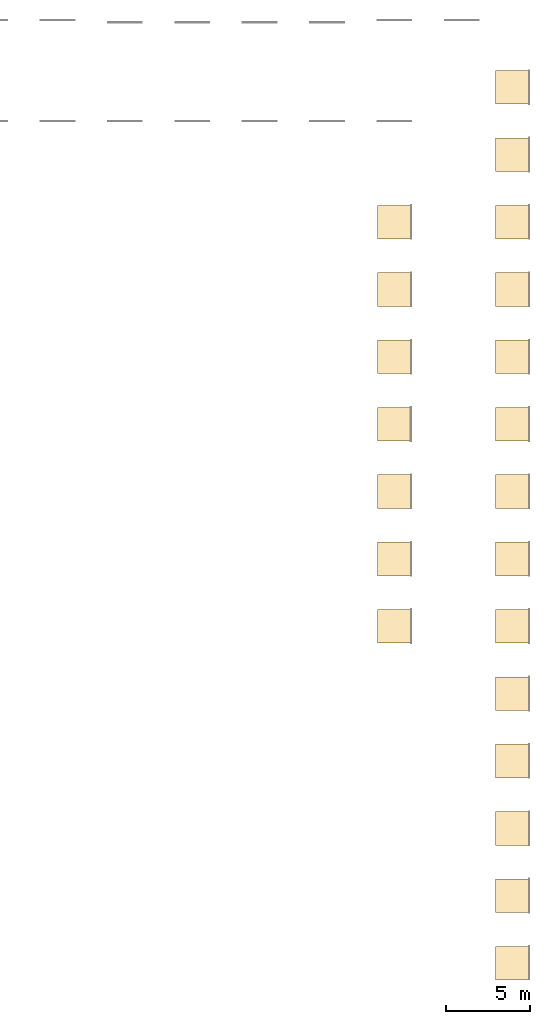
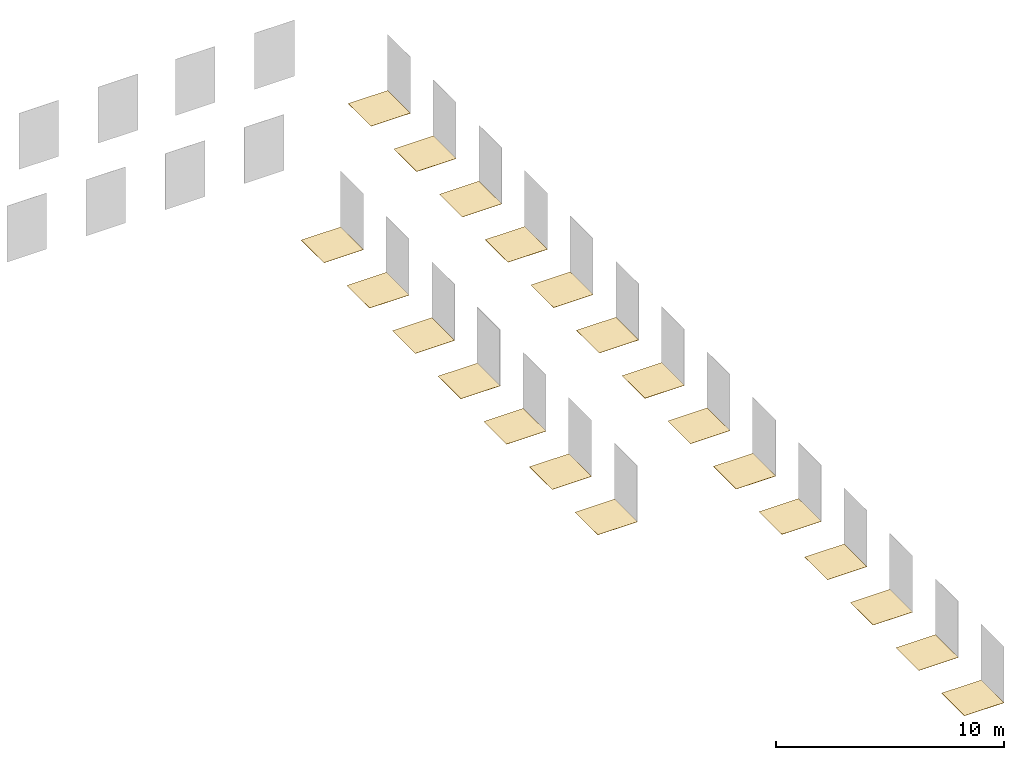
# One storey, part 2 of 2: 21 coverings.
"""IFC2X3 building model written with IfcOpenShell, lengths in millimetres."""

from ifc_helpers import new_model, entity, si_unit, converted_unit, derived_unit, direction, frame, frame_2d, origin, place, context, subcontext, project, spatial, rectangle, extrude, material, layer, layer_set, layer_usage, element, save


model = new_model("IFC2X3")

# Units and contexts
model_context = context("Model", 3, precision=0.01, world=origin(), true_north=direction((6.12303176911189e-17, 1.0)))
body_context = subcontext(model_context, "Body", "Model", "MODEL_VIEW")
ifc_project = project(units=[si_unit("LENGTHUNIT", "METRE", prefix="MILLI"), si_unit("AREAUNIT", "SQUARE_METRE"), si_unit("VOLUMEUNIT", "CUBIC_METRE"), converted_unit("PLANEANGLEUNIT", "DEGREE", entity("IfcRatioMeasure", 0.0174532925199433), si_unit("PLANEANGLEUNIT", "RADIAN"), dimensions=[0, 0, 0, 0, 0, 0, 0]), si_unit("MASSUNIT", "GRAM", prefix="KILO"), derived_unit("MASSDENSITYUNIT", [(si_unit("MASSUNIT", "GRAM", prefix="KILO"), 1), (si_unit("LENGTHUNIT", "METRE"), -3)]), si_unit("TIMEUNIT", "SECOND"), si_unit("FREQUENCYUNIT", "HERTZ"), si_unit("THERMODYNAMICTEMPERATUREUNIT", "DEGREE_CELSIUS"), derived_unit("THERMALTRANSMITTANCEUNIT", [(si_unit("MASSUNIT", "GRAM", prefix="KILO"), 1), (si_unit("THERMODYNAMICTEMPERATUREUNIT", "KELVIN"), -1), (si_unit("TIMEUNIT", "SECOND"), -3)]), derived_unit("VOLUMETRICFLOWRATEUNIT", [(si_unit("LENGTHUNIT", "METRE"), 3), (si_unit("TIMEUNIT", "SECOND"), -1)]), si_unit("ELECTRICCURRENTUNIT", "AMPERE"), si_unit("ELECTRICVOLTAGEUNIT", "VOLT"), si_unit("POWERUNIT", "WATT"), si_unit("FORCEUNIT", "NEWTON", prefix="KILO"), si_unit("ILLUMINANCEUNIT", "LUX"), si_unit("LUMINOUSFLUXUNIT", "LUMEN"), si_unit("LUMINOUSINTENSITYUNIT", "CANDELA"), derived_unit("USERDEFINED", [(si_unit("MASSUNIT", "GRAM", prefix="KILO"), -1), (si_unit("LENGTHUNIT", "METRE"), -2), (si_unit("TIMEUNIT", "SECOND"), 3), (si_unit("LUMINOUSFLUXUNIT", "LUMEN"), 1)]), derived_unit("LINEARVELOCITYUNIT", [(si_unit("LENGTHUNIT", "METRE"), 1), (si_unit("TIMEUNIT", "SECOND"), -1)]), si_unit("PRESSUREUNIT", "PASCAL"), derived_unit("USERDEFINED", [(si_unit("LENGTHUNIT", "METRE"), -2), (si_unit("MASSUNIT", "GRAM", prefix="KILO"), 1), (si_unit("TIMEUNIT", "SECOND"), -2)])], contexts=[model_context])

# Site, building, storey
site_placement = place(None, origin())
site = spatial("IfcSite", under=ifc_project, at=site_placement, CompositionType="ELEMENT")
building_placement = place(site_placement, origin())
building = spatial("IfcBuilding", under=site, at=building_placement, CompositionType="ELEMENT")
storey_placement = place(building_placement, origin())
storey = spatial("IfcBuildingStorey", under=building, at=storey_placement, Name="Level 1", CompositionType="ELEMENT", Elevation=0.0)

# Coverings
ifc_material_1 = material()
ifc_layer_1 = layer(ifc_material_1, 10.5)
ifc_layer_set_1 = layer_set([ifc_layer_1])
ifc_layer_usage_1 = layer_usage(ifc_layer_set_1, "AXIS3", "POSITIVE", 0.0)
covering_1_placement = place(storey_placement, origin())
element("IfcCovering", 1, at=covering_1_placement, inside=storey, material=ifc_layer_usage_1, PredefinedType="FLOORING", context=body_context, shape_type="SweptSolid", body=[
    extrude(rectangle(XDim=2000.0, YDim=2000.0, at=frame_2d((2.8421709430404e-13, 1.13686837721616e-13), x_axis=(1.0, 0.0))), frame((2527.07742659013, -3501.98267476882, 0.0), z_axis=(0.0, 0.0, -1.0), x_axis=(0.0, 1.0, 0.0)), (0.0, 0.0, 1.0), 10.5),
])
ifc_material_2 = material()
ifc_layer_2 = layer(ifc_material_2, 10.5)
ifc_layer_set_2 = layer_set([ifc_layer_2])
ifc_layer_usage_2 = layer_usage(ifc_layer_set_2, "AXIS3", "POSITIVE", 0.0)
covering_2_placement = place(storey_placement, origin())
element("IfcCovering", 2, at=covering_2_placement, inside=storey, material=ifc_layer_usage_2, PredefinedType="FLOORING", context=body_context, shape_type="SweptSolid", body=[
    extrude(rectangle(XDim=2000.0, YDim=2000.0, at=frame_2d((5.6843418860808e-13, 1.13686837721616e-13), x_axis=(1.0, 0.0))), frame((2527.07742659012, -7501.98267476882, 0.0), z_axis=(0.0, 0.0, -1.0), x_axis=(0.0, 1.0, 0.0)), (0.0, 0.0, 1.0), 10.5),
])
ifc_material_3 = material()
ifc_layer_3 = layer(ifc_material_3, 10.5)
ifc_layer_set_3 = layer_set([ifc_layer_3])
ifc_layer_usage_3 = layer_usage(ifc_layer_set_3, "AXIS3", "POSITIVE", 0.0)
covering_3_placement = place(storey_placement, origin())
element("IfcCovering", 3, at=covering_3_placement, inside=storey, material=ifc_layer_usage_3, PredefinedType="FLOORING", context=body_context, shape_type="SweptSolid", body=[
    extrude(rectangle(XDim=2000.0, YDim=2000.0, at=frame_2d((-2.8421709430404e-13, 1.13686837721616e-13), x_axis=(1.0, 0.0))), frame((2527.07742659014, 4498.01732523118, 0.0), z_axis=(0.0, 0.0, -1.0), x_axis=(0.0, 1.0, 0.0)), (0.0, 0.0, 1.0), 10.5),
])
ifc_material_4 = material()
ifc_layer_4 = layer(ifc_material_4, 10.5)
ifc_layer_set_4 = layer_set([ifc_layer_4])
ifc_layer_usage_4 = layer_usage(ifc_layer_set_4, "AXIS3", "POSITIVE", 0.0)
covering_4_placement = place(storey_placement, origin())
element("IfcCovering", 4, at=covering_4_placement, inside=storey, material=ifc_layer_usage_4, PredefinedType="FLOORING", context=body_context, shape_type="SweptSolid", body=[
    extrude(rectangle(XDim=2000.0, YDim=2000.0, at=frame_2d((-1.13686837721616e-13, 1.13686837721616e-13), x_axis=(1.0, 0.0))), frame((2527.07742659014, 498.017325231177, 0.0), z_axis=(0.0, 0.0, -1.0), x_axis=(0.0, 1.0, 0.0)), (0.0, 0.0, 1.0), 10.5),
])
ifc_material_5 = material()
ifc_layer_5 = layer(ifc_material_5, 10.5)
ifc_layer_set_5 = layer_set([ifc_layer_5])
ifc_layer_usage_5 = layer_usage(ifc_layer_set_5, "AXIS3", "POSITIVE", 0.0)
covering_5_placement = place(storey_placement, origin())
element("IfcCovering", 5, at=covering_5_placement, inside=storey, material=ifc_layer_usage_5, PredefinedType="FLOORING", context=body_context, shape_type="SweptSolid", body=[
    extrude(rectangle(XDim=2000.0, YDim=2000.0, at=frame_2d((0.0, 1.13686837721616e-13), x_axis=(1.0, 0.0))), frame((2527.07742659012, -11501.9826747688, 0.0), z_axis=(0.0, 0.0, -1.0), x_axis=(0.0, 1.0, 0.0)), (0.0, 0.0, 1.0), 10.5),
])
ifc_material_6 = material()
ifc_layer_6 = layer(ifc_material_6, 10.5)
ifc_layer_set_6 = layer_set([ifc_layer_6])
ifc_layer_usage_6 = layer_usage(ifc_layer_set_6, "AXIS3", "POSITIVE", 0.0)
covering_6_placement = place(storey_placement, origin())
element("IfcCovering", 6, at=covering_6_placement, inside=storey, material=ifc_layer_usage_6, PredefinedType="FLOORING", context=body_context, shape_type="SweptSolid", body=[
    extrude(rectangle(XDim=2000.0, YDim=2000.0, at=frame_2d((0.0, 1.13686837721616e-13), x_axis=(1.0, 0.0))), frame((2527.07742659011, -15501.9826747688, 0.0), z_axis=(0.0, 0.0, -1.0), x_axis=(0.0, 1.0, 0.0)), (0.0, 0.0, 1.0), 10.5),
])
ifc_material_7 = material()
ifc_layer_7 = layer(ifc_material_7, 11.5)
ifc_layer_set_7 = layer_set([ifc_layer_7])
ifc_layer_usage_7 = layer_usage(ifc_layer_set_7, "AXIS3", "POSITIVE", 0.0)
covering_7_placement = place(storey_placement, origin())
element("IfcCovering", 7, at=covering_7_placement, inside=storey, material=ifc_layer_usage_7, PredefinedType="FLOORING", context=body_context, shape_type="SweptSolid", body=[
    extrude(rectangle(XDim=2000.0, YDim=2000.0, at=frame_2d((0.0, 1.13686837721616e-13), x_axis=(1.0, 0.0))), frame((2527.07742659011, -19501.9826747688, 0.0), z_axis=(0.0, 0.0, -1.0), x_axis=(0.0, 1.0, 0.0)), (0.0, 0.0, 1.0), 11.5),
])
ifc_material_8 = material()
ifc_layer_8 = layer(ifc_material_8, 11.5)
ifc_layer_set_8 = layer_set([ifc_layer_8])
ifc_layer_usage_8 = layer_usage(ifc_layer_set_8, "AXIS3", "POSITIVE", 0.0)
covering_8_placement = place(storey_placement, origin())
element("IfcCovering", 8, at=covering_8_placement, inside=storey, material=ifc_layer_usage_8, PredefinedType="FLOORING", context=body_context, shape_type="SweptSolid", body=[
    extrude(rectangle(XDim=2000.0, YDim=2000.0, at=frame_2d((0.0, 1.13686837721616e-13), x_axis=(1.0, 0.0))), frame((2527.0774265901, -23501.9826747688, 0.0), z_axis=(0.0, 0.0, -1.0), x_axis=(0.0, 1.0, 0.0)), (0.0, 0.0, 1.0), 11.5),
])
ifc_material_9 = material()
ifc_layer_9 = layer(ifc_material_9, 11.5)
ifc_layer_set_9 = layer_set([ifc_layer_9])
ifc_layer_usage_9 = layer_usage(ifc_layer_set_9, "AXIS3", "POSITIVE", 0.0)
covering_9_placement = place(storey_placement, origin())
element("IfcCovering", 9, at=covering_9_placement, inside=storey, material=ifc_layer_usage_9, PredefinedType="CLADDING", context=body_context, shape_type="SweptSolid", body=[
    extrude(rectangle(XDim=2000.0, YDim=2000.0, at=frame_2d((0.0, 1.13686837721616e-13), x_axis=(1.0, 0.0))), frame((2527.07742659009, -27501.9826747688, 0.0), z_axis=(0.0, 0.0, -1.0), x_axis=(0.0, 1.0, 0.0)), (0.0, 0.0, 1.0), 11.5),
])
ifc_material_10 = material()
ifc_layer_10 = layer(ifc_material_10, 11.5)
ifc_layer_set_10 = layer_set([ifc_layer_10])
ifc_layer_usage_10 = layer_usage(ifc_layer_set_10, "AXIS3", "POSITIVE", 0.0)
covering_10_placement = place(storey_placement, origin())
element("IfcCovering", 10, at=covering_10_placement, inside=storey, material=ifc_layer_usage_10, PredefinedType="FLOORING", context=body_context, shape_type="SweptSolid", body=[
    extrude(rectangle(XDim=2000.0, YDim=2000.0, at=frame_2d((0.0, 1.13686837721616e-13), x_axis=(1.0, 0.0))), frame((2527.07742659009, -31501.9826747688, 0.0), z_axis=(0.0, 0.0, -1.0), x_axis=(0.0, 1.0, 0.0)), (0.0, 0.0, 1.0), 11.5),
])
ifc_material_11 = material()
ifc_layer_11 = layer(ifc_material_11, 9.4)
ifc_layer_set_11 = layer_set([ifc_layer_11])
ifc_layer_usage_11 = layer_usage(ifc_layer_set_11, "AXIS3", "POSITIVE", 0.0)
covering_11_placement = place(storey_placement, origin())
element("IfcCovering", 11, at=covering_11_placement, inside=storey, material=ifc_layer_usage_11, PredefinedType="FLOORING", context=body_context, shape_type="SweptSolid", body=[
    extrude(rectangle(XDim=2000.0, YDim=2000.0, at=frame_2d((0.0, 1.13686837721616e-13), x_axis=(1.0, 0.0))), frame((2527.07742659008, -35501.9826747688, 0.0), z_axis=(0.0, 0.0, -1.0), x_axis=(0.0, 1.0, 0.0)), (0.0, 0.0, 1.0), 9.4),
])
ifc_material_12 = material()
ifc_layer_12 = layer(ifc_material_12, 9.4)
ifc_layer_set_12 = layer_set([ifc_layer_12])
ifc_layer_usage_12 = layer_usage(ifc_layer_set_12, "AXIS3", "POSITIVE", 0.0)
covering_12_placement = place(storey_placement, origin())
element("IfcCovering", 12, at=covering_12_placement, inside=storey, material=ifc_layer_usage_12, PredefinedType="FLOORING", context=body_context, shape_type="SweptSolid", body=[
    extrude(rectangle(XDim=2000.0, YDim=2000.0, at=frame_2d((2.1600499167107e-12, 1.13686837721616e-13), x_axis=(1.0, 0.0))), frame((2527.07742659007, -39501.9826747688, 0.0), z_axis=(0.0, 0.0, -1.0), x_axis=(0.0, 1.0, 0.0)), (0.0, 0.0, 1.0), 9.4),
])
ifc_material_13 = material()
ifc_layer_13 = layer(ifc_material_13, 9.4)
ifc_layer_set_13 = layer_set([ifc_layer_13])
ifc_layer_usage_13 = layer_usage(ifc_layer_set_13, "AXIS3", "POSITIVE", 0.0)
covering_13_placement = place(storey_placement, origin())
element("IfcCovering", 13, at=covering_13_placement, inside=storey, material=ifc_layer_usage_13, PredefinedType="FLOORING", context=body_context, shape_type="SweptSolid", body=[
    extrude(rectangle(XDim=2000.0, YDim=2000.0, at=frame_2d((4.32009983342141e-12, 1.13686837721616e-13), x_axis=(1.0, 0.0))), frame((2527.07742659007, -43501.9826747688, 0.0), z_axis=(0.0, 0.0, -1.0), x_axis=(0.0, 1.0, 0.0)), (0.0, 0.0, 1.0), 9.4),
])
ifc_material_14 = material()
ifc_layer_14 = layer(ifc_material_14, 10.5)
ifc_layer_set_14 = layer_set([ifc_layer_14])
ifc_layer_usage_14 = layer_usage(ifc_layer_set_14, "AXIS3", "POSITIVE", 0.0)
covering_14_placement = place(storey_placement, origin())
element("IfcCovering", 14, at=covering_14_placement, inside=storey, material=ifc_layer_usage_14, PredefinedType="FLOORING", context=body_context, shape_type="SweptSolid", body=[
    extrude(rectangle(XDim=2000.0, YDim=2000.0, at=frame_2d((-4.32009983342141e-12, 1.13686837721616e-13), x_axis=(1.0, 0.0))), frame((2527.07742659006, -47501.9826747688, 0.0), z_axis=(0.0, 0.0, -1.0), x_axis=(0.0, 1.0, 0.0)), (0.0, 0.0, 1.0), 10.5),
])
ifc_material_15 = material()
ifc_layer_15 = layer(ifc_material_15, 10.0)
ifc_layer_set_15 = layer_set([ifc_layer_15])
ifc_layer_usage_15 = layer_usage(ifc_layer_set_15, "AXIS3", "POSITIVE", 0.0)
covering_15_placement = place(storey_placement, origin())
element("IfcCovering", 15, at=covering_15_placement, inside=storey, material=ifc_layer_usage_15, PredefinedType="FLOORING", context=body_context, shape_type="SweptSolid", body=[
    extrude(rectangle(XDim=2000.0, YDim=2000.0, at=frame_2d((2.27373675443232e-13, -5.11590769747272e-13), x_axis=(1.0, 0.0))), frame((-4472.92257340986, -3501.98267476882, 0.0), z_axis=(0.0, 0.0, -1.0), x_axis=(0.0, 1.0, 0.0)), (0.0, 0.0, 1.0), 10.0),
])
ifc_material_16 = material()
ifc_layer_16 = layer(ifc_material_16, 10.0)
ifc_layer_set_16 = layer_set([ifc_layer_16])
ifc_layer_usage_16 = layer_usage(ifc_layer_set_16, "AXIS3", "POSITIVE", 0.0)
covering_16_placement = place(storey_placement, origin())
element("IfcCovering", 16, at=covering_16_placement, inside=storey, material=ifc_layer_usage_16, PredefinedType="FLOORING", context=body_context, shape_type="SweptSolid", body=[
    extrude(rectangle(XDim=2000.0, YDim=2000.00000000001, at=frame_2d((5.11590769747272e-13, 0.0), x_axis=(1.0, 0.0))), frame((-4472.92257340986, -7501.98267476882, 0.0), z_axis=(0.0, 0.0, -1.0), x_axis=(0.0, 1.0, 0.0)), (0.0, 0.0, 1.0), 10.0),
])
ifc_material_17 = material()
ifc_layer_17 = layer(ifc_material_17, 9.4)
ifc_layer_set_17 = layer_set([ifc_layer_17])
ifc_layer_usage_17 = layer_usage(ifc_layer_set_17, "AXIS3", "POSITIVE", 0.0)
covering_17_placement = place(storey_placement, origin())
element("IfcCovering", 17, at=covering_17_placement, inside=storey, material=ifc_layer_usage_17, PredefinedType="FLOORING", context=body_context, shape_type="SweptSolid", body=[
    extrude(rectangle(XDim=2000.0, YDim=2000.0, at=frame_2d((0.0, -5.11590769747272e-13), x_axis=(1.0, 0.0))), frame((-4472.92257340986, -11501.9826747688, 0.0), z_axis=(0.0, 0.0, -1.0), x_axis=(0.0, 1.0, 0.0)), (0.0, 0.0, 1.0), 9.4),
])
ifc_material_18 = material()
ifc_layer_18 = layer(ifc_material_18, 10.0)
ifc_layer_set_18 = layer_set([ifc_layer_18])
ifc_layer_usage_18 = layer_usage(ifc_layer_set_18, "AXIS3", "POSITIVE", 0.0)
covering_18_placement = place(storey_placement, origin())
element("IfcCovering", 18, at=covering_18_placement, inside=storey, material=ifc_layer_usage_18, PredefinedType="FLOORING", context=body_context, shape_type="SweptSolid", body=[
    extrude(rectangle(XDim=2000.0, YDim=2000.0, at=frame_2d((0.0, -5.11590769747272e-13), x_axis=(1.0, 0.0))), frame((-4472.92257340986, -15501.9826747688, 0.0), z_axis=(0.0, 0.0, -1.0), x_axis=(0.0, 1.0, 0.0)), (0.0, 0.0, 1.0), 10.0),
])
ifc_material_19 = material()
ifc_layer_19 = layer(ifc_material_19, 9.4)
ifc_layer_set_19 = layer_set([ifc_layer_19])
ifc_layer_usage_19 = layer_usage(ifc_layer_set_19, "AXIS3", "POSITIVE", 0.0)
covering_19_placement = place(storey_placement, origin())
element("IfcCovering", 19, at=covering_19_placement, inside=storey, material=ifc_layer_usage_19, PredefinedType="FLOORING", context=body_context, shape_type="SweptSolid", body=[
    extrude(rectangle(XDim=2000.0, YDim=2000.0, at=frame_2d((0.0, -5.11590769747272e-13), x_axis=(1.0, 0.0))), frame((-4472.92257340986, -19501.9826747688, 0.0), z_axis=(0.0, 0.0, -1.0), x_axis=(0.0, 1.0, 0.0)), (0.0, 0.0, 1.0), 9.4),
])
ifc_material_20 = material()
ifc_layer_20 = layer(ifc_material_20, 10.0)
ifc_layer_set_20 = layer_set([ifc_layer_20])
ifc_layer_usage_20 = layer_usage(ifc_layer_set_20, "AXIS3", "POSITIVE", 0.0)
covering_20_placement = place(storey_placement, origin())
element("IfcCovering", 20, at=covering_20_placement, inside=storey, material=ifc_layer_usage_20, PredefinedType="FLOORING", context=body_context, shape_type="SweptSolid", body=[
    extrude(rectangle(XDim=2000.0, YDim=2000.0, at=frame_2d((2.1600499167107e-12, -5.11590769747272e-13), x_axis=(1.0, 0.0))), frame((-4472.92257340986, -23501.9826747688, 0.0), z_axis=(0.0, 0.0, -1.0), x_axis=(0.0, 1.0, 0.0)), (0.0, 0.0, 1.0), 10.0),
])
ifc_material_21 = material()
ifc_layer_21 = layer(ifc_material_21, 9.4)
ifc_layer_set_21 = layer_set([ifc_layer_21])
ifc_layer_usage_21 = layer_usage(ifc_layer_set_21, "AXIS3", "POSITIVE", 0.0)
covering_21_placement = place(storey_placement, origin())
element("IfcCovering", 21, at=covering_21_placement, inside=storey, material=ifc_layer_usage_21, PredefinedType="FLOORING", context=body_context, shape_type="SweptSolid", body=[
    extrude(rectangle(XDim=2000.0, YDim=2000.0, at=frame_2d((-2.1600499167107e-12, -5.11590769747272e-13), x_axis=(1.0, 0.0))), frame((-4472.92257340986, -27501.9826747688, 0.0), z_axis=(0.0, 0.0, -1.0), x_axis=(0.0, 1.0, 0.0)), (0.0, 0.0, 1.0), 9.4),
])

save(model, "model.ifc")
